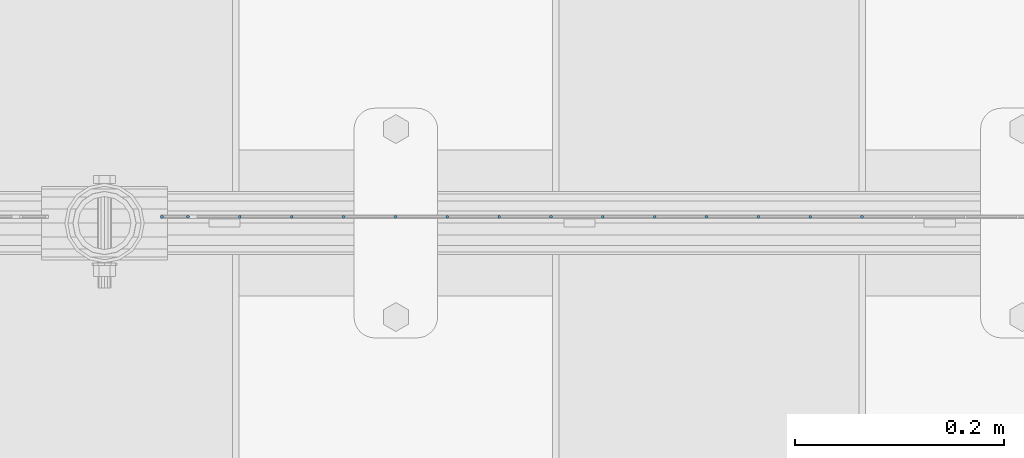
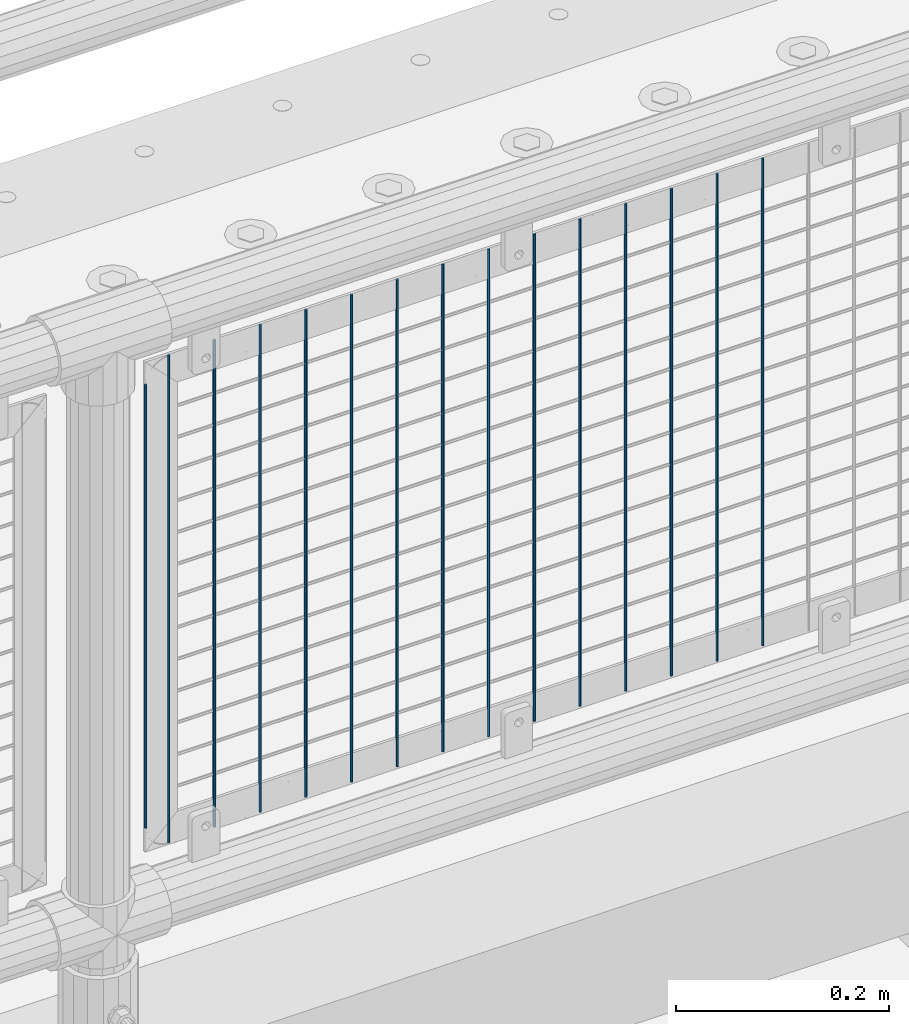
# One storey, part 58 of 208: 15 columns.
"""IFC2X3 building model written with IfcOpenShell, lengths in millimetres."""

from ifc_helpers import new_model, si_unit, frame, origin_with_axes, place, context, subcontext, project, spatial, faceted_brep, material, type_object, element, save


model = new_model("IFC2X3")

# Units and contexts
model_context = context("Model", 3, precision=1e-05, world=origin_with_axes())
body_context = subcontext(model_context, "Body", "Model", "MODEL_VIEW")
ifc_project = project(units=[si_unit("LENGTHUNIT", "METRE", prefix="MILLI"), si_unit("AREAUNIT", "SQUARE_METRE"), si_unit("VOLUMEUNIT", "CUBIC_METRE"), si_unit("MASSUNIT", "GRAM", prefix="KILO"), si_unit("TIMEUNIT", "SECOND"), si_unit("PLANEANGLEUNIT", "RADIAN"), si_unit("SOLIDANGLEUNIT", "STERADIAN"), si_unit("THERMODYNAMICTEMPERATUREUNIT", "DEGREE_CELSIUS"), si_unit("LUMINOUSINTENSITYUNIT", "LUMEN")], contexts=[model_context])

# Site, building, storey
site_placement = place(None, origin_with_axes())
site = spatial("IfcSite", under=ifc_project, at=site_placement, CompositionType="ELEMENT")
building_placement = place(site_placement, origin_with_axes())
building = spatial("IfcBuilding", under=site, at=building_placement, Name="Standard", CompositionType="ELEMENT")
storey_placement = place(building_placement, origin_with_axes())
storey = spatial("IfcBuildingStorey", under=building, at=storey_placement, Name="Undefined", CompositionType="ELEMENT", Elevation=0.0)

# Columns
ifc_material = material(Name="Misc_Undefined")
column_type = type_object("IfcColumnType", Name="D3", PredefinedType="NOTDEFINED")
for number, where, z_axis, x_axis in (
    (1, (-39503.485, 4670.5, 353.02), (-1.0, 0.0, 0.0), (0.0, 0.0, 1.0)),
    (2, (-39553.14, 4670.5, 353.02), (-1.0, 0.0, 0.0), (0.0, 0.0, 1.0)),
    (3, (-39602.795, 4670.5, 353.02), (-1.0, 0.0, 0.0), (0.0, 0.0, 1.0)),
    (4, (-39652.45, 4670.5, 353.02), (-1.0, 0.0, 0.0), (0.0, 0.0, 1.0)),
    (5, (-39702.105, 4670.5, 353.02), (-1.0, 0.0, 0.0), (0.0, 0.0, 1.0)),
    (6, (-39751.76, 4670.5, 353.02), (-1.0, 0.0, 0.0), (0.0, 0.0, 1.0)),
    (7, (-39801.415, 4670.5, 353.02), (-1.0, 0.0, 0.0), (0.0, 0.0, 1.0)),
    (8, (-39851.07, 4670.5, 353.02), (-1.0, 0.0, 0.0), (0.0, 0.0, 1.0)),
    (9, (-39900.725, 4670.5, 353.02), (-1.0, 0.0, 0.0), (0.0, 0.0, 1.0)),
    (10, (-39950.38, 4670.5, 353.02), (-1.0, 0.0, 0.0), (0.0, 0.0, 1.0)),
    (11, (-40000.035, 4670.5, 353.02), (-1.0, 0.0, 0.0), (0.0, 0.0, 1.0)),
    (12, (-40049.6896551724, 4670.5, 353.02), (-1.0, 0.0, 0.0), (0.0, 0.0, 1.0)),
    (13, (-40099.3448275862, 4670.5, 353.02), (-0.999999999962839, 0.0, 8.62099999968473e-06), (8.62099999949798e-06, 0.0, 0.999999999962839)),
):
    element("IfcColumn", number, at=place(storey_placement, frame(where, z_axis=z_axis, x_axis=x_axis)), inside=storey, type_object=column_type, material=ifc_material, ObjectType="D3", context=body_context, shape_type="Brep", body=[
        faceted_brep([(0.0, -1.49999999999909, 3.63797880709171e-12), (-7.27595761418343e-12, -0.749999999999091, -1.29903810567669), (560.0, -0.75, -1.29903810567703), (560.0, -1.5, 0.0), (-3.63797880709171e-12, 0.750000000000909, -1.29903810567669), (560.0, 0.75, -1.29903810567703), (0.0, 1.50000000000182, 3.63797880709171e-12), (560.0, 1.5, 0.0), (-3.63797880709171e-12, 0.750000000000909, 1.29903810567669), (560.0, 0.75, 1.29903810567703), (-7.27595761418343e-12, -0.749999999999091, 1.29903810567669), (560.0, -0.75, 1.29903810567703)], [[[0, 1, 2, 3]], [[1, 4, 5, 2]], [[4, 6, 7, 5]], [[6, 8, 9, 7]], [[8, 10, 11, 9]], [[10, 0, 3, 11]], [[5, 7, 9, 11, 3, 2]], [[10, 8, 6, 4, 1, 0]]]),
    ])
column_1_placement = place(storey_placement, frame((-40174.0, 4670.5, 378.02), z_axis=(-1.0, 0.0, 0.0), x_axis=(0.0, 0.0, 1.0)))
element("IfcColumn", 14, at=column_1_placement, inside=storey, type_object=column_type, material=ifc_material, ObjectType="D3", context=body_context, shape_type="Brep", body=[
    faceted_brep([(0.0, -1.49999999999909, 3.63797880709171e-12), (-7.27595761418343e-12, -0.749999999999091, -1.29903810567669), (510.0, -0.75, -1.29903810567703), (510.0, -1.5, 0.0), (-3.63797880709171e-12, 0.750000000000909, -1.29903810567669), (510.0, 0.75, -1.29903810567703), (0.0, 1.50000000000182, 3.63797880709171e-12), (510.0, 1.5, 0.0), (-3.63797880709171e-12, 0.750000000000909, 1.29903810567669), (510.0, 0.75, 1.29903810567703), (-7.27595761418343e-12, -0.749999999999091, 1.29903810567669), (510.0, -0.75, 1.29903810567703)], [[[0, 1, 2, 3]], [[1, 4, 5, 2]], [[4, 6, 7, 5]], [[6, 8, 9, 7]], [[8, 10, 11, 9]], [[10, 0, 3, 11]], [[5, 7, 9, 11, 3, 2]], [[10, 8, 6, 4, 1, 0]]]),
])
column_2_placement = place(storey_placement, frame((-40149.0, 4670.5, 353.02), z_axis=(-1.0, 0.0, 0.0), x_axis=(0.0, 0.0, 1.0)))
element("IfcColumn", 15, at=column_2_placement, inside=storey, type_object=column_type, material=ifc_material, ObjectType="D3", context=body_context, shape_type="Brep", body=[
    faceted_brep([(0.0, -1.49999999999909, 3.63797880709171e-12), (-7.27595761418343e-12, -0.749999999999091, -1.29903810567669), (560.0, -0.75, -1.29903810567703), (560.0, -1.5, 0.0), (-3.63797880709171e-12, 0.750000000000909, -1.29903810567669), (560.0, 0.75, -1.29903810567703), (0.0, 1.50000000000182, 3.63797880709171e-12), (560.0, 1.5, 0.0), (-3.63797880709171e-12, 0.750000000000909, 1.29903810567669), (560.0, 0.75, 1.29903810567703), (-7.27595761418343e-12, -0.749999999999091, 1.29903810567669), (560.0, -0.75, 1.29903810567703)], [[[0, 1, 2, 3]], [[1, 4, 5, 2]], [[4, 6, 7, 5]], [[6, 8, 9, 7]], [[8, 10, 11, 9]], [[10, 0, 3, 11]], [[5, 7, 9, 11, 3, 2]], [[10, 8, 6, 4, 1, 0]]]),
])

save(model, "model.ifc")
